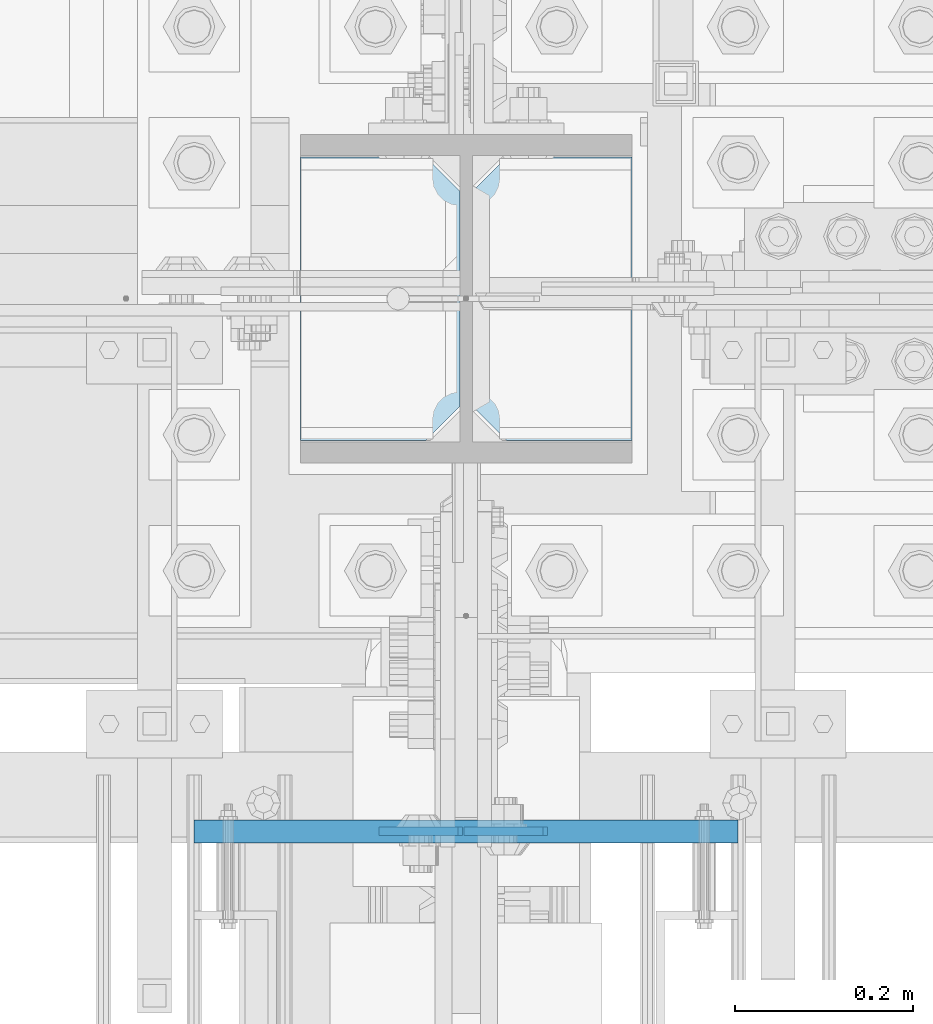
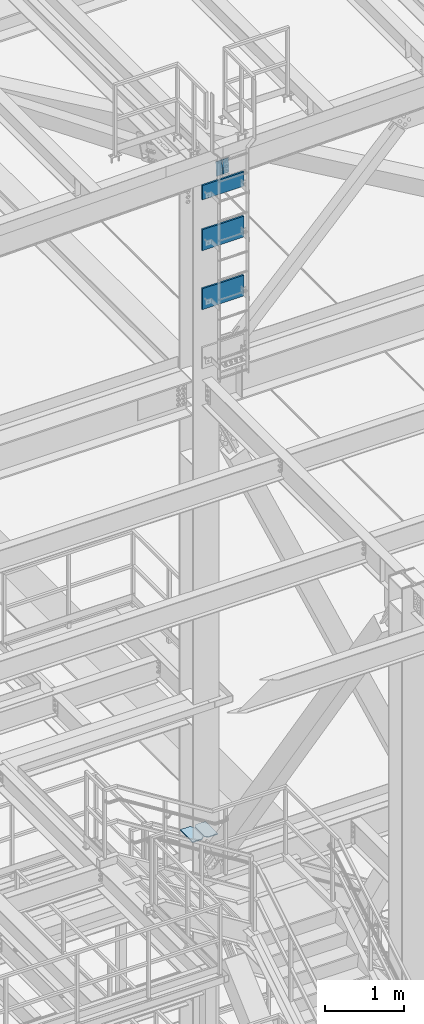
# One storey, part 3147 of 3843: 7 plates, 5 elements without a shape of their own.
"""IFC2X3 building model written with IfcOpenShell, lengths in millimetres."""

from ifc_helpers import new_model, si_unit, frame, origin_with_axes, place, context, subcontext, project, spatial, faceted_brep, material, type_object, element, aggregate, save


model = new_model("IFC2X3")

# Units and contexts
model_context = context("Model", 3, precision=1e-05, world=origin_with_axes())
body_context = subcontext(model_context, "Body", "Model", "MODEL_VIEW")
ifc_project = project(units=[si_unit("LENGTHUNIT", "METRE", prefix="MILLI"), si_unit("AREAUNIT", "SQUARE_METRE"), si_unit("VOLUMEUNIT", "CUBIC_METRE"), si_unit("MASSUNIT", "GRAM", prefix="KILO"), si_unit("TIMEUNIT", "SECOND"), si_unit("PLANEANGLEUNIT", "RADIAN"), si_unit("SOLIDANGLEUNIT", "STERADIAN"), si_unit("THERMODYNAMICTEMPERATUREUNIT", "DEGREE_CELSIUS"), si_unit("LUMINOUSINTENSITYUNIT", "LUMEN")], contexts=[model_context])

# Site, building, storey
site_placement = place(None, origin_with_axes())
site = spatial("IfcSite", under=ifc_project, at=site_placement, CompositionType="ELEMENT")
building_placement = place(site_placement, origin_with_axes())
building = spatial("IfcBuilding", under=site, at=building_placement, Name="Undefined", CompositionType="ELEMENT")
storey_placement = place(building_placement, origin_with_axes())
storey = spatial("IfcBuildingStorey", under=building, at=storey_placement, Name="Undefined", CompositionType="ELEMENT", Elevation=0.0)

# Assembly, plate
assembly_1_placement = place(storey_placement, origin_with_axes())
assembly_1 = element("IfcElementAssembly", 1, at=assembly_1_placement, inside=storey, Name="PLYWOOD", AssemblyPlace="NOTDEFINED", PredefinedType="NOTDEFINED")
ifc_material_1 = material(Name="TIMBER/PLYWOOD")
plate_type_1 = type_object("IfcPlateType", PredefinedType="NOTDEFINED")
plate_1_placement = place(assembly_1_placement, frame((55930.7997224927, 25031.6333618165, 44208.7), z_axis=(0.0, 0.0, -1.0), x_axis=(0.0, -1.0, 0.0)))
plate_1 = element("IfcPlate", 2, at=plate_1_placement, type_object=plate_type_1, material=ifc_material_1, Name="PLYWOOD", context=body_context, shape_type="Brep", body=[
    faceted_brep([(0.0, -304.799999999999, 0.0), (0.0, -304.800000000003, 323.849999999999), (0.0, 304.800000000003, 323.849999999999), (0.0, 304.799999999999, 0.0), (25.3999999999942, -304.800000000003, 323.849999999999), (25.3999999999942, 304.800000000003, 323.849999999999), (25.4000000002561, -304.799999999999, -8.00355337560177e-11), (25.4000000002561, 304.799999999999, -8.00355337560177e-11)], [[[0, 1, 2, 3]], [[1, 4, 5, 2]], [[4, 6, 7, 5]], [[6, 0, 3, 7]], [[5, 7, 3, 2]], [[6, 4, 1, 0]]]),
])
aggregate(assembly_1, [plate_1])

assembly_2_placement = place(storey_placement, origin_with_axes())
assembly_2 = element("IfcElementAssembly", 3, at=assembly_2_placement, inside=storey, Name="PLYWOOD", AssemblyPlace="NOTDEFINED", PredefinedType="NOTDEFINED")
plate_2_placement = place(assembly_2_placement, frame((55930.7997224927, 25031.6333618165, 45123.1), z_axis=(0.0, 0.0, -1.0), x_axis=(0.0, -1.0, 0.0)))
plate_2 = element("IfcPlate", 4, at=plate_2_placement, type_object=plate_type_1, material=ifc_material_1, Name="PLYWOOD", context=body_context, shape_type="Brep", body=[
    faceted_brep([(0.0, -304.799999999999, 0.0), (0.0, -304.800000000003, 323.849999999999), (0.0, 304.800000000003, 323.849999999999), (0.0, 304.799999999999, 0.0), (25.3999999999942, -304.800000000003, 323.849999999999), (25.3999999999942, 304.800000000003, 323.849999999999), (25.4000000002561, -304.799999999999, -8.00355337560177e-11), (25.4000000002561, 304.799999999999, -8.00355337560177e-11)], [[[0, 1, 2, 3]], [[1, 4, 5, 2]], [[4, 6, 7, 5]], [[6, 0, 3, 7]], [[5, 7, 3, 2]], [[6, 4, 1, 0]]]),
])
aggregate(assembly_2, [plate_2])

assembly_3_placement = place(storey_placement, origin_with_axes())
assembly_3 = element("IfcElementAssembly", 5, at=assembly_3_placement, inside=storey, Name="PLYWOOD", AssemblyPlace="NOTDEFINED", PredefinedType="NOTDEFINED")
plate_3_placement = place(assembly_3_placement, frame((55930.7997224927, 25031.6333618165, 45808.9), z_axis=(0.0, 0.0, -1.0), x_axis=(0.0, -1.0, 0.0)))
plate_3 = element("IfcPlate", 6, at=plate_3_placement, type_object=plate_type_1, material=ifc_material_1, Name="PLYWOOD", context=body_context, shape_type="Brep", body=[
    faceted_brep([(0.0, -304.799999999999, 0.0), (0.0, -304.800000000003, 222.249999999993), (0.0, 304.800000000003, 222.249999999993), (0.0, 304.799999999999, 0.0), (25.3999999999942, -304.800000000003, 222.249999999993), (25.3999999999942, 304.800000000003, 222.249999999993), (25.4000000002561, -304.799999999999, -8.00355337560177e-11), (25.4000000002561, 304.799999999999, -8.00355337560177e-11)], [[[0, 1, 2, 3]], [[1, 4, 5, 2]], [[4, 6, 7, 5]], [[6, 0, 3, 7]], [[5, 7, 3, 2]], [[6, 4, 1, 0]]]),
])
aggregate(assembly_3, [plate_3])

# Assembly, plates
assembly_4_placement = place(storey_placement, origin_with_axes())
assembly_4 = element("IfcElementAssembly", 7, at=assembly_4_placement, inside=storey, Name="BEAM", AssemblyPlace="NOTDEFINED", PredefinedType="RIGID_FRAME")
ifc_material_2 = material(Name="STEEL/A572-50")
plate_type_2 = type_object("IfcPlateType", PredefinedType="NOTDEFINED")
plate_4_placement = place(assembly_4_placement, frame((55928.1991026056, 25019.0000000844, 46100.9173187994), z_axis=(0.999776270257024, 0.0, 0.0211520550054619), x_axis=(0.0211520550054438, 0.0, -0.999776270257025)))
plate_4 = element("IfcPlate", 8, at=plate_4_placement, type_object=plate_type_2, material=ifc_material_2, Name="PLATE", context=body_context, shape_type="Brep", body=[
    faceted_brep([(0.0, -4.76249999999709, 0.0), (0.0, -4.76249999999709, 88.9000015258789), (0.0, 4.76249999999709, 88.9000015258789), (0.0, 4.76249999999709, 0.0), (228.600006102781, -4.7625000004191, 88.9000015257589), (228.600006102781, 4.76249999954598, 88.9000015257443), (228.600006103079, -4.7625000004482, 7.27595761418343e-12), (228.600006103079, 4.76249999954598, -7.27595761418343e-12)], [[[0, 1, 2, 3]], [[1, 4, 5, 2]], [[4, 6, 7, 5]], [[6, 0, 3, 7]], [[5, 7, 3, 2]], [[6, 4, 1, 0]]]),
])
plate_5_placement = place(assembly_4_placement, frame((55921.8503105163, 25019.0000000627, 46100.7829972327), z_axis=(-0.999776270257024, 0.0, -0.0211520550054595), x_axis=(0.0211520550054438, 0.0, -0.999776270257025)))
plate_5 = element("IfcPlate", 9, at=plate_5_placement, type_object=plate_type_2, material=ifc_material_2, Name="PLATE", context=body_context, shape_type="Brep", body=[
    faceted_brep([(0.0, -4.76249999999709, 0.0), (0.0, -4.76249999999709, 88.9000015258789), (0.0, 4.76249999999709, 88.9000015258789), (0.0, 4.76249999999709, 0.0), (228.600006102781, -4.7625000004191, 88.9000015257589), (228.600006102781, 4.76249999954598, 88.9000015257443), (228.600006103079, -4.7625000004482, 7.27595761418343e-12), (228.600006103079, 4.76249999954598, -7.27595761418343e-12)], [[[0, 1, 2, 3]], [[1, 4, 5, 2]], [[4, 6, 7, 5]], [[6, 0, 3, 7]], [[5, 7, 3, 2]], [[6, 4, 1, 0]]]),
])
aggregate(assembly_4, [plate_4, plate_5])

assembly_5_placement = place(storey_placement, origin_with_axes())
assembly_5 = element("IfcElementAssembly", 10, at=assembly_5_placement, inside=storey, Name="COLUMN", AssemblyPlace="NOTDEFINED", PredefinedType="RIGID_FRAME")
plate_type_3 = type_object("IfcPlateType", PredefinedType="NOTDEFINED")
plate_6_placement = place(assembly_5_placement, frame((55745.0625, 25457.15, 35314.8936300372), z_axis=(0.0, 1.0, 0.0), x_axis=(1.0, 0.0, 0.0)))
plate_6 = element("IfcPlate", 11, at=plate_6_placement, type_object=plate_type_3, material=ifc_material_2, Name="STIFFENER", context=body_context, shape_type="Brep", body=[
    faceted_brep([(0.0, -6.3499999046162, 0.0), (0.0, -6.34999999999854, 317.5), (0.0, 6.34999999999854, 317.5), (7.27595761418343e-12, 6.3499999046162, 0.0), (140.493751525879, -6.34999999999854, 317.5), (140.493751525879, 6.34999999999854, 317.5), (178.59375, -6.34999999999854, 279.400001525879), (178.59375, 6.34999999999854, 279.400001525879), (178.59375, -6.34999999999854, 38.0999984741211), (178.59375, 6.34999999999854, 38.0999984741211), (140.493751525879, -6.34999999999854, 0.0), (140.493751525879, 6.34999999999854, 0.0)], [[[0, 1, 2, 3]], [[1, 4, 5, 2]], [[4, 6, 7, 5]], [[6, 8, 9, 7]], [[8, 10, 11, 9]], [[10, 0, 3, 11]], [[5, 7, 9, 11, 3, 2]], [[10, 8, 6, 4, 1, 0]]]),
])
plate_7_placement = place(assembly_5_placement, frame((55937.94375, 25457.15, 35314.8936300372), z_axis=(0.0, 1.0, 0.0), x_axis=(1.0, 0.0, 0.0)))
plate_7 = element("IfcPlate", 12, at=plate_7_placement, type_object=plate_type_3, material=ifc_material_2, Name="STIFFENER", context=body_context, shape_type="Brep", body=[
    faceted_brep([(0.0, -6.34999999999854, 38.0999984741211), (0.0, -6.34999999999854, 279.400001525879), (0.0, 6.34999999999854, 279.400001525879), (0.0, 6.34999999999854, 38.0999984741211), (38.0999984741211, -6.34999999999854, 317.5), (38.0999984741211, 6.34999999999854, 317.5), (178.59375, -6.34999999999854, 317.5), (178.59375, 6.34999999999854, 317.5), (178.59375, -6.34999999999854, 0.0), (178.59375, 6.34999999999854, 0.0), (38.0999984741211, -6.34999999999854, 0.0), (38.0999984741211, 6.34999999999854, 0.0)], [[[0, 1, 2, 3]], [[1, 4, 5, 2]], [[4, 6, 7, 5]], [[6, 8, 9, 7]], [[8, 10, 11, 9]], [[10, 0, 3, 11]], [[5, 7, 9, 11, 3, 2]], [[10, 8, 6, 4, 1, 0]]]),
])
aggregate(assembly_5, [plate_6, plate_7])

save(model, "model.ifc")
